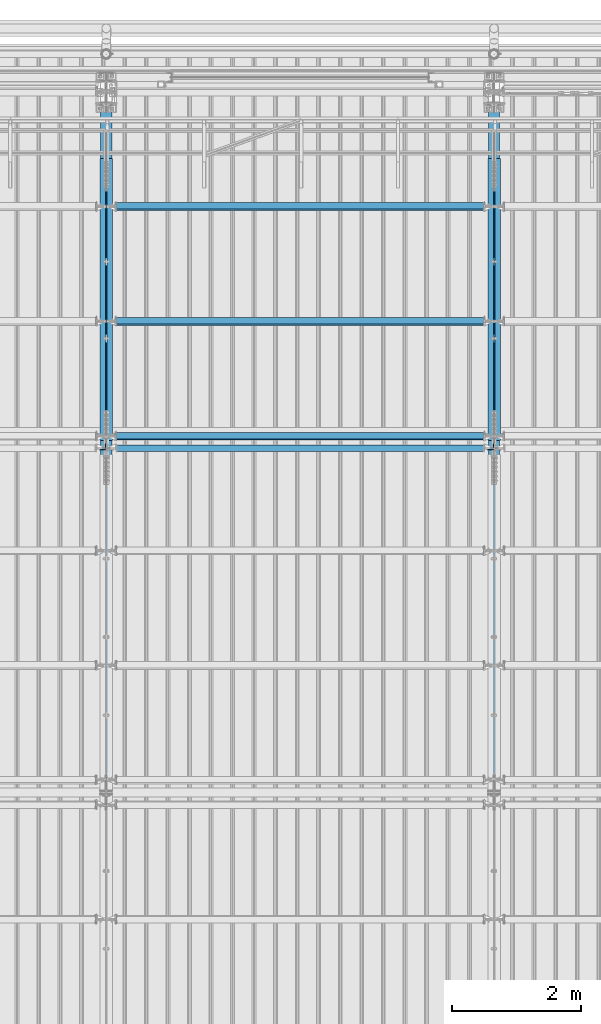
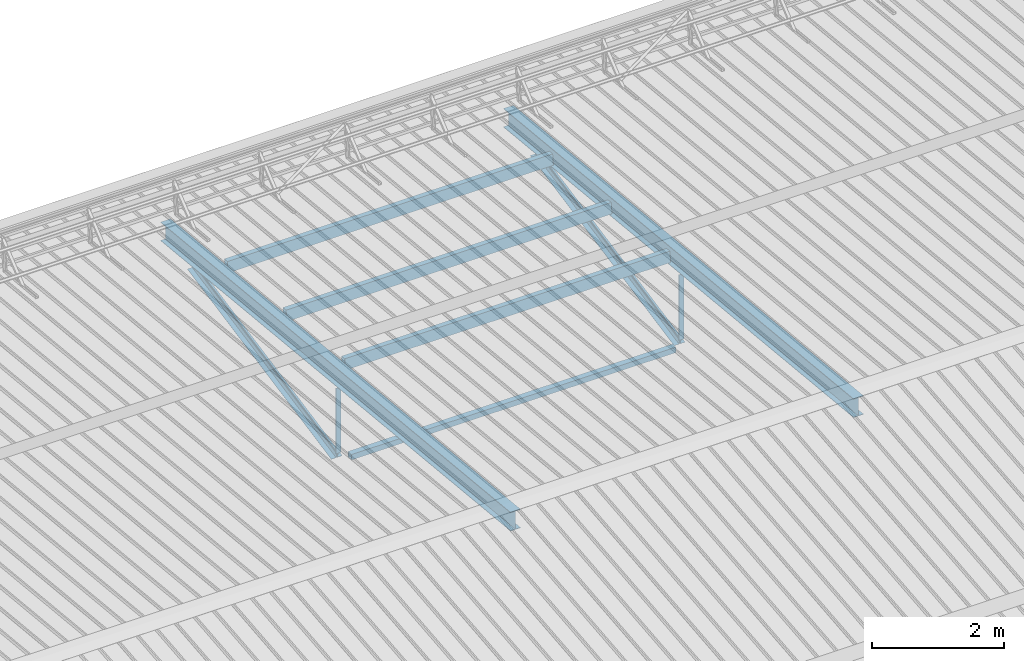
# One storey, part 267 of 709: 12 beams, 12 elements without a shape of their own.
"""IFC4 building model written with IfcOpenShell, lengths in millimetres."""

from ifc_helpers import new_model, si_unit, direction, frame, origin_with_axes, place, context, subcontext, project, spatial, polygons, material, element, aggregate, save


model = new_model("IFC4")

# Units and contexts
model_context = context("Model", 3, precision=0.2, world=origin_with_axes(), true_north=direction((0.0, 1.0)))
body_context = subcontext(model_context, "Body", "Model", "MODEL_VIEW")
ifc_project = project(units=[si_unit("LENGTHUNIT", "METRE", prefix="MILLI"), si_unit("AREAUNIT", "SQUARE_METRE"), si_unit("VOLUMEUNIT", "CUBIC_METRE"), si_unit("MASSUNIT", "GRAM", prefix="KILO"), si_unit("TIMEUNIT", "SECOND"), si_unit("PLANEANGLEUNIT", "RADIAN"), si_unit("SOLIDANGLEUNIT", "STERADIAN"), si_unit("THERMODYNAMICTEMPERATUREUNIT", "DEGREE_CELSIUS"), si_unit("LUMINOUSINTENSITYUNIT", "LUMEN")], contexts=[model_context])

# Site, building, storey
site_placement = place(None, origin_with_axes())
site = spatial("IfcSite", under=ifc_project, at=site_placement, CompositionType="ELEMENT")
building_placement = place(site_placement, origin_with_axes())
building = spatial("IfcBuilding", under=site, at=building_placement, Name="Undefined", CompositionType="ELEMENT")
storey_placement = place(building_placement, origin_with_axes())
storey = spatial("IfcBuildingStorey", under=building, at=storey_placement, Name="Undefined", CompositionType="ELEMENT", Elevation=0.0)

# Assembly, beam
assembly_1_placement = place(storey_placement, frame((16000.0, 21654.0, 7089.70002), z_axis=(-1.0, 0.0, 0.0), x_axis=(0.0, -0.9950371902, 0.099503719)))
assembly_1 = element("IfcElementAssembly", 1, at=assembly_1_placement, inside=storey)
ifc_material_1 = material(Name="C355-5", Category="STEEL")
beam_1_placement = place(assembly_1_placement, origin_with_axes())
beam_1 = element("IfcBeam", 2, at=beam_1_placement, material=ifc_material_1, ObjectType="432", context=body_context, shape_type="Tessellation", body=[
    polygons([(3.80474, -173.0, -87.0), (4.70474, -164.0, -87.0), (10665.6128, -164.0, -87.0), (10664.7128, -173.0, -87.0), (4.70474, -164.0, -3.0), (10665.6128, -164.0, -3.0), (37.50474, 164.0, -3.0), (10698.4128, 164.0, -3.0), (37.50474, 164.0, -87.0), (10698.4128, 164.0, -87.0), (38.40474, 173.0, -87.0), (10699.3128, 173.0, -87.0), (38.40474, 173.0, 87.0), (10699.3128, 173.0, 87.0), (37.50474, 164.0, 87.0), (10698.4128, 164.0, 87.0), (37.50474, 164.0, 3.0), (10698.4128, 164.0, 3.0), (4.70474, -164.0, 3.0), (10665.6128, -164.0, 3.0), (4.70474, -164.0, 87.0), (10665.6128, -164.0, 87.0), (3.80474, -173.0, 87.0), (10664.7128, -173.0, 87.0)], [[[1, 2, 3, 4]], [[2, 5, 6, 3]], [[5, 7, 8, 6]], [[7, 9, 10, 8]], [[9, 11, 12, 10]], [[11, 13, 14, 12]], [[13, 15, 16, 14]], [[15, 17, 18, 16]], [[17, 19, 20, 18]], [[19, 21, 22, 20]], [[21, 23, 24, 22]], [[23, 1, 4, 24]], [[6, 8, 10, 12, 14, 16, 18, 20, 22, 24, 4, 3]], [[23, 21, 19, 17, 15, 13, 11, 9, 7, 5, 2, 1]]], closed=True),
])
aggregate(assembly_1, [beam_1])

assembly_2_placement = place(storey_placement, frame((16051.0, 21649.9404, 7109.99804), z_axis=(0.0, -0.1961161349, 0.9805806757), x_axis=(0.0, -0.9805806757, -0.1961161349)))
assembly_2 = element("IfcElementAssembly", 3, at=assembly_2_placement, inside=storey)
ifc_material_2 = material(Name="C345-5", Category="STEEL")
beam_2_placement = place(assembly_2_placement, origin_with_axes())
beam_2 = element("IfcBeam", 4, at=beam_2_placement, material=ifc_material_2, ObjectType="444", context=body_context, shape_type="Tessellation", body=[
    polygons([(868.11437, -45.0, -45.0), (868.11437, 45.0, -45.0), (5317.375, 45.0, -45.0), (5317.375, -45.0, -45.0), (868.11437, 45.0, -39.0), (5317.375, 45.0, -39.0), (868.11437, -39.0, -39.0), (5317.375, -39.0, -39.0), (868.11437, -39.0, 45.0), (5317.375, -39.0, 45.0), (868.11437, -45.0, 45.0), (5317.375, -45.0, 45.0)], [[[1, 2, 3, 4]], [[2, 5, 6, 3]], [[5, 7, 8, 6]], [[7, 9, 10, 8]], [[9, 11, 12, 10]], [[11, 1, 4, 12]], [[6, 8, 10, 12, 4, 3]], [[11, 9, 7, 5, 2, 1]]], closed=True),
])
aggregate(assembly_2, [beam_2])

assembly_3_placement = place(storey_placement, frame((15949.0, 16322.9404, 6044.59804), z_axis=(0.0, -0.1961161349, 0.9805806757), x_axis=(0.0, 0.9805806757, 0.1961161349)))
assembly_3 = element("IfcElementAssembly", 5, at=assembly_3_placement, inside=storey)
beam_3_placement = place(assembly_3_placement, origin_with_axes())
beam_3 = element("IfcBeam", 6, at=beam_3_placement, material=ifc_material_2, ObjectType="444", context=body_context, shape_type="Tessellation", body=[
    polygons([(115.12039, -45.0, -45.0), (115.12039, 45.0, -45.0), (4564.38102, 45.0, -45.0), (4564.38102, -45.0, -45.0), (115.12039, 45.0, -39.0), (4564.38102, 45.0, -39.0), (115.12039, -39.0, -39.0), (4564.38102, -39.0, -39.0), (115.12039, -39.0, 45.0), (4564.38102, -39.0, 45.0), (115.12039, -45.0, 45.0), (4564.38102, -45.0, 45.0)], [[[1, 2, 3, 4]], [[2, 5, 6, 3]], [[5, 7, 8, 6]], [[7, 9, 10, 8]], [[9, 11, 12, 10]], [[11, 1, 4, 12]], [[6, 8, 10, 12, 4, 3]], [[11, 9, 7, 5, 2, 1]]], closed=True),
])
aggregate(assembly_3, [beam_3])

assembly_4_placement = place(storey_placement, frame((15949.0, 16347.7, 7622.40002), z_axis=(0.0, 1.0, 0.0), x_axis=(0.0, 0.0, -1.0)))
assembly_4 = element("IfcElementAssembly", 7, at=assembly_4_placement, inside=storey)
beam_4_placement = place(assembly_4_placement, origin_with_axes())
beam_4 = element("IfcBeam", 8, at=beam_4_placement, material=ifc_material_2, ObjectType="436", context=body_context, shape_type="Tessellation", body=[
    polygons([(198.6891, -45.0, -45.0), (198.6891, 45.0, -45.0), (1412.4, 45.0, -45.0), (1412.4, -45.0, -45.0), (198.6891, 45.0, -39.0), (1412.4, 45.0, -39.0), (198.6891, -39.0, -39.0), (1412.4, -39.0, -39.0), (198.6891, -39.0, 45.0), (1412.4, -39.0, 45.0), (198.6891, -45.0, 45.0), (1412.4, -45.0, 45.0)], [[[1, 2, 3, 4]], [[2, 5, 6, 3]], [[5, 7, 8, 6]], [[7, 9, 10, 8]], [[9, 11, 12, 10]], [[11, 1, 4, 12]], [[6, 8, 10, 12, 4, 3]], [[11, 9, 7, 5, 2, 1]]], closed=True),
])
aggregate(assembly_4, [beam_4])

assembly_5_placement = place(storey_placement, frame((22000.0, 21654.0, 7089.70002), z_axis=(-1.0, 0.0, 0.0), x_axis=(0.0, -0.9950371902, 0.099503719)))
assembly_5 = element("IfcElementAssembly", 9, at=assembly_5_placement, inside=storey)
beam_5_placement = place(assembly_5_placement, origin_with_axes())
beam_5 = element("IfcBeam", 10, at=beam_5_placement, material=ifc_material_1, ObjectType="432", context=body_context, shape_type="Tessellation", body=[
    polygons([(3.80474, -173.0, -87.0), (4.70474, -164.0, -87.0), (10665.6128, -164.0, -87.0), (10664.7128, -173.0, -87.0), (4.70474, -164.0, -3.0), (10665.6128, -164.0, -3.0), (37.50474, 164.0, -3.0), (10698.4128, 164.0, -3.0), (37.50474, 164.0, -87.0), (10698.4128, 164.0, -87.0), (38.40474, 173.0, -87.0), (10699.3128, 173.0, -87.0), (38.40474, 173.0, 87.0), (10699.3128, 173.0, 87.0), (37.50474, 164.0, 87.0), (10698.4128, 164.0, 87.0), (37.50474, 164.0, 3.0), (10698.4128, 164.0, 3.0), (4.70474, -164.0, 3.0), (10665.6128, -164.0, 3.0), (4.70474, -164.0, 87.0), (10665.6128, -164.0, 87.0), (3.80474, -173.0, 87.0), (10664.7128, -173.0, 87.0)], [[[1, 2, 3, 4]], [[2, 5, 6, 3]], [[5, 7, 8, 6]], [[7, 9, 10, 8]], [[9, 11, 12, 10]], [[11, 13, 14, 12]], [[13, 15, 16, 14]], [[15, 17, 18, 16]], [[17, 19, 20, 18]], [[19, 21, 22, 20]], [[21, 23, 24, 22]], [[23, 1, 4, 24]], [[6, 8, 10, 12, 14, 16, 18, 20, 22, 24, 4, 3]], [[23, 21, 19, 17, 15, 13, 11, 9, 7, 5, 2, 1]]], closed=True),
])
aggregate(assembly_5, [beam_5])

assembly_6_placement = place(storey_placement, frame((22051.0, 21649.9404, 7109.99804), z_axis=(0.0, -0.1961161349, 0.9805806757), x_axis=(0.0, -0.9805806757, -0.1961161349)))
assembly_6 = element("IfcElementAssembly", 11, at=assembly_6_placement, inside=storey)
beam_6_placement = place(assembly_6_placement, origin_with_axes())
beam_6 = element("IfcBeam", 12, at=beam_6_placement, material=ifc_material_2, ObjectType="444", context=body_context, shape_type="Tessellation", body=[
    polygons([(868.11437, -45.0, -45.0), (868.11437, 45.0, -45.0), (5317.375, 45.0, -45.0), (5317.375, -45.0, -45.0), (868.11437, 45.0, -39.0), (5317.375, 45.0, -39.0), (868.11437, -39.0, -39.0), (5317.375, -39.0, -39.0), (868.11437, -39.0, 45.0), (5317.375, -39.0, 45.0), (868.11437, -45.0, 45.0), (5317.375, -45.0, 45.0)], [[[1, 2, 3, 4]], [[2, 5, 6, 3]], [[5, 7, 8, 6]], [[7, 9, 10, 8]], [[9, 11, 12, 10]], [[11, 1, 4, 12]], [[6, 8, 10, 12, 4, 3]], [[11, 9, 7, 5, 2, 1]]], closed=True),
])
aggregate(assembly_6, [beam_6])

assembly_7_placement = place(storey_placement, frame((21949.0, 16322.9404, 6044.59804), z_axis=(0.0, -0.1961161349, 0.9805806757), x_axis=(0.0, 0.9805806757, 0.1961161349)))
assembly_7 = element("IfcElementAssembly", 13, at=assembly_7_placement, inside=storey)
beam_7_placement = place(assembly_7_placement, origin_with_axes())
beam_7 = element("IfcBeam", 14, at=beam_7_placement, material=ifc_material_2, ObjectType="444", context=body_context, shape_type="Tessellation", body=[
    polygons([(115.12039, -45.0, -45.0), (115.12039, 45.0, -45.0), (4564.38102, 45.0, -45.0), (4564.38102, -45.0, -45.0), (115.12039, 45.0, -39.0), (4564.38102, 45.0, -39.0), (115.12039, -39.0, -39.0), (4564.38102, -39.0, -39.0), (115.12039, -39.0, 45.0), (4564.38102, -39.0, 45.0), (115.12039, -45.0, 45.0), (4564.38102, -45.0, 45.0)], [[[1, 2, 3, 4]], [[2, 5, 6, 3]], [[5, 7, 8, 6]], [[7, 9, 10, 8]], [[9, 11, 12, 10]], [[11, 1, 4, 12]], [[6, 8, 10, 12, 4, 3]], [[11, 9, 7, 5, 2, 1]]], closed=True),
])
aggregate(assembly_7, [beam_7])

assembly_8_placement = place(storey_placement, frame((21949.0, 16347.7, 7622.40002), z_axis=(0.0, 1.0, 0.0), x_axis=(0.0, 0.0, -1.0)))
assembly_8 = element("IfcElementAssembly", 15, at=assembly_8_placement, inside=storey)
beam_8_placement = place(assembly_8_placement, origin_with_axes())
beam_8 = element("IfcBeam", 16, at=beam_8_placement, material=ifc_material_2, ObjectType="436", context=body_context, shape_type="Tessellation", body=[
    polygons([(198.6891, -45.0, -45.0), (198.6891, 45.0, -45.0), (1412.4, 45.0, -45.0), (1412.4, -45.0, -45.0), (198.6891, 45.0, -39.0), (1412.4, 45.0, -39.0), (198.6891, -39.0, -39.0), (1412.4, -39.0, -39.0), (198.6891, -39.0, 45.0), (1412.4, -39.0, 45.0), (198.6891, -45.0, 45.0), (1412.4, -45.0, 45.0)], [[[1, 2, 3, 4]], [[2, 5, 6, 3]], [[5, 7, 8, 6]], [[7, 9, 10, 8]], [[9, 11, 12, 10]], [[11, 1, 4, 12]], [[6, 8, 10, 12, 4, 3]], [[11, 9, 7, 5, 2, 1]]], closed=True),
])
aggregate(assembly_8, [beam_8])

assembly_9_placement = place(storey_placement, frame((16000.0, 16327.0, 6074.30002), z_axis=(0.0, -1.0, 0.0), x_axis=(1.0, 0.0, 0.0)))
assembly_9 = element("IfcElementAssembly", 17, at=assembly_9_placement, inside=storey)
ifc_material_3 = material(Name="C355", Category="STEEL")
beam_9_placement = place(assembly_9_placement, origin_with_axes())
beam_9 = element("IfcBeam", 18, at=beam_9_placement, material=ifc_material_3, ObjectType="557", context=body_context, shape_type="Tessellation", body=[
    polygons([(162.0, -47.0, -47.0), (162.0, -47.0, 47.0), (5838.0, -47.0, 47.0), (5838.0, -47.0, -47.0), (162.0, 47.0, 47.0), (5838.0, 47.0, 47.0), (162.0, 47.0, -47.0), (5838.0, 47.0, -47.0), (162.0, -50.0, -50.0), (162.0, 50.0, -50.0), (5838.0, 50.0, -50.0), (5838.0, -50.0, -50.0), (162.0, 50.0, 50.0), (5838.0, 50.0, 50.0), (162.0, -50.0, 50.0), (5838.0, -50.0, 50.0)], [[[1, 2, 3, 4]], [[2, 5, 6, 3]], [[5, 7, 8, 6]], [[7, 1, 4, 8]], [[9, 10, 11, 12]], [[10, 13, 14, 11]], [[13, 15, 16, 14]], [[15, 9, 12, 16]], [[14, 16, 12, 11], [6, 8, 4, 3]], [[15, 13, 10, 9], [7, 5, 2, 1]]], closed=True),
])
aggregate(assembly_9, [beam_9])

assembly_10_placement = place(storey_placement, frame((22000.0, 16509.95037, 7677.46908), z_axis=(0.0, -0.9950371902, 0.099503719), x_axis=(-1.0, 0.0, 0.0)))
assembly_10 = element("IfcElementAssembly", 19, at=assembly_10_placement, inside=storey)
beam_10_placement = place(assembly_10_placement, origin_with_axes())
beam_10 = element("IfcBeam", 20, at=beam_10_placement, material=ifc_material_3, ObjectType="579", context=body_context, shape_type="Tessellation", body=[
    polygons([(155.0, -96.0, -46.0), (155.0, -96.0, 46.0), (5845.0, -96.0, 46.0), (5845.0, -96.0, -46.0), (155.0, 96.0, 46.0), (5845.0, 96.0, 46.0), (155.0, 96.0, -46.0), (5845.0, 96.0, -46.0), (155.0, -100.0, -50.0), (155.0, 100.0, -50.0), (5845.0, 100.0, -50.0), (5845.0, -100.0, -50.0), (155.0, 100.0, 50.0), (5845.0, 100.0, 50.0), (155.0, -100.0, 50.0), (5845.0, -100.0, 50.0)], [[[1, 2, 3, 4]], [[2, 5, 6, 3]], [[5, 7, 8, 6]], [[7, 1, 4, 8]], [[9, 10, 11, 12]], [[10, 13, 14, 11]], [[13, 15, 16, 14]], [[15, 9, 12, 16]], [[14, 16, 12, 11], [6, 8, 4, 3]], [[15, 13, 10, 9], [7, 5, 2, 1]]], closed=True),
])
aggregate(assembly_10, [beam_10])

assembly_11_placement = place(storey_placement, frame((22000.0, 18286.65012, 7499.7991), z_axis=(0.0, -0.9950371902, 0.099503719), x_axis=(-1.0, 0.0, 0.0)))
assembly_11 = element("IfcElementAssembly", 21, at=assembly_11_placement, inside=storey)
beam_11_placement = place(assembly_11_placement, origin_with_axes())
beam_11 = element("IfcBeam", 22, at=beam_11_placement, material=ifc_material_3, ObjectType="579", context=body_context, shape_type="Tessellation", body=[
    polygons([(155.0, -96.0, -46.0), (155.0, -96.0, 46.0), (5845.0, -96.0, 46.0), (5845.0, -96.0, -46.0), (155.0, 96.0, 46.0), (5845.0, 96.0, 46.0), (155.0, 96.0, -46.0), (5845.0, 96.0, -46.0), (155.0, -100.0, -50.0), (155.0, 100.0, -50.0), (5845.0, 100.0, -50.0), (5845.0, -100.0, -50.0), (155.0, 100.0, 50.0), (5845.0, 100.0, 50.0), (155.0, -100.0, 50.0), (5845.0, -100.0, 50.0)], [[[1, 2, 3, 4]], [[2, 5, 6, 3]], [[5, 7, 8, 6]], [[7, 1, 4, 8]], [[9, 10, 11, 12]], [[10, 13, 14, 11]], [[13, 15, 16, 14]], [[15, 9, 12, 16]], [[14, 16, 12, 11], [6, 8, 4, 3]], [[15, 13, 10, 9], [7, 5, 2, 1]]], closed=True),
])
aggregate(assembly_11, [beam_11])

assembly_12_placement = place(storey_placement, frame((22000.0, 20063.34988, 7322.12913), z_axis=(0.0, -0.9950371902, 0.099503719), x_axis=(-1.0, 0.0, 0.0)))
assembly_12 = element("IfcElementAssembly", 23, at=assembly_12_placement, inside=storey)
beam_12_placement = place(assembly_12_placement, origin_with_axes())
beam_12 = element("IfcBeam", 24, at=beam_12_placement, material=ifc_material_3, ObjectType="579", context=body_context, shape_type="Tessellation", body=[
    polygons([(155.0, -96.0, -46.0), (155.0, -96.0, 46.0), (5845.0, -96.0, 46.0), (5845.0, -96.0, -46.0), (155.0, 96.0, 46.0), (5845.0, 96.0, 46.0), (155.0, 96.0, -46.0), (5845.0, 96.0, -46.0), (155.0, -100.0, -50.0), (155.0, 100.0, -50.0), (5845.0, 100.0, -50.0), (5845.0, -100.0, -50.0), (155.0, 100.0, 50.0), (5845.0, 100.0, 50.0), (155.0, -100.0, 50.0), (5845.0, -100.0, 50.0)], [[[1, 2, 3, 4]], [[2, 5, 6, 3]], [[5, 7, 8, 6]], [[7, 1, 4, 8]], [[9, 10, 11, 12]], [[10, 13, 14, 11]], [[13, 15, 16, 14]], [[15, 9, 12, 16]], [[14, 16, 12, 11], [6, 8, 4, 3]], [[15, 13, 10, 9], [7, 5, 2, 1]]], closed=True),
])
aggregate(assembly_12, [beam_12])

save(model, "model.ifc")
